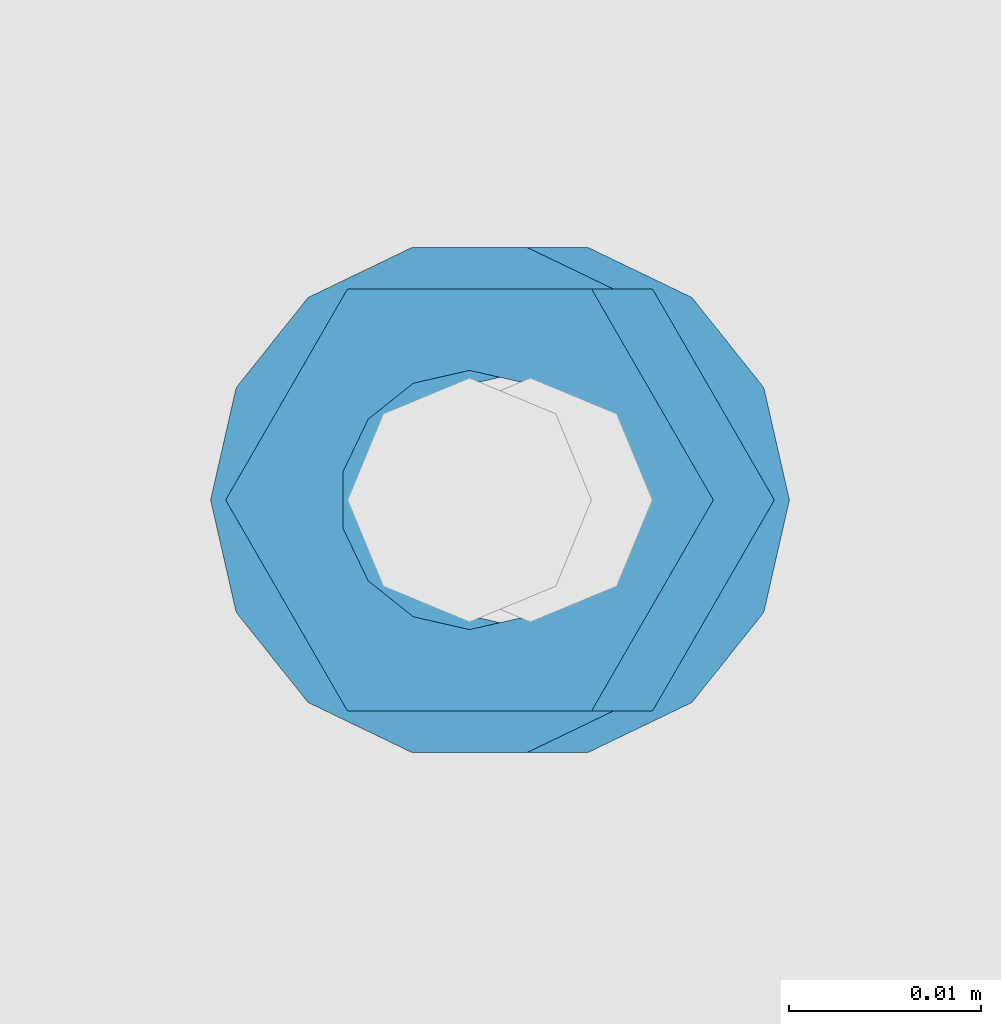
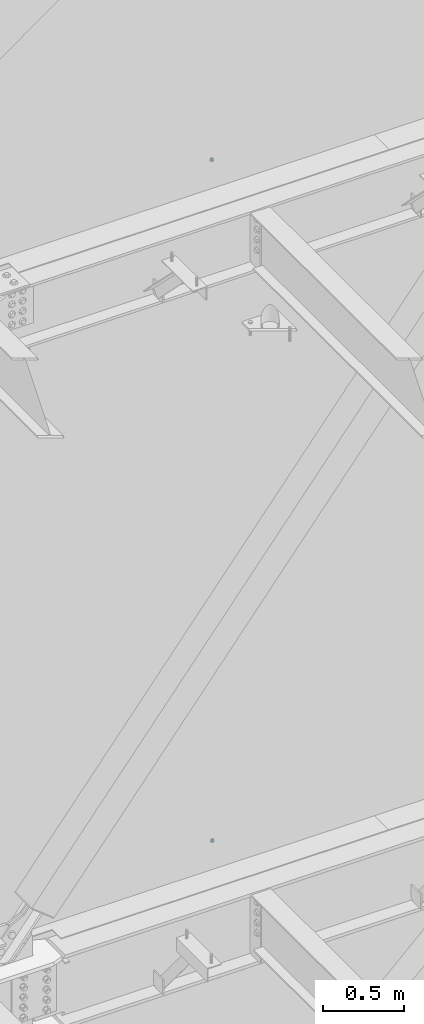
# One storey, part 668 of 1179: 4 columns, 2 elements without a shape of their own.
"""IFC2X3 building model written with IfcOpenShell, lengths in millimetres."""

from ifc_helpers import new_model, si_unit, frame, origin_with_axes, place, context, subcontext, project, spatial, faceted_brep, material, type_object, element, aggregate, save


model = new_model("IFC2X3")

# Units and contexts
model_context = context("Model", 3, precision=1e-05, world=origin_with_axes())
body_context = subcontext(model_context, "Body", "Model", "MODEL_VIEW")
ifc_project = project(units=[si_unit("LENGTHUNIT", "METRE", prefix="MILLI"), si_unit("AREAUNIT", "SQUARE_METRE"), si_unit("VOLUMEUNIT", "CUBIC_METRE"), si_unit("MASSUNIT", "GRAM", prefix="KILO"), si_unit("TIMEUNIT", "SECOND"), si_unit("PLANEANGLEUNIT", "RADIAN"), si_unit("SOLIDANGLEUNIT", "STERADIAN"), si_unit("THERMODYNAMICTEMPERATUREUNIT", "DEGREE_CELSIUS"), si_unit("LUMINOUSINTENSITYUNIT", "LUMEN")], contexts=[model_context])

# Site, building, storey
site_placement = place(None, origin_with_axes())
site = spatial("IfcSite", under=ifc_project, at=site_placement, CompositionType="ELEMENT")
building_placement = place(site_placement, origin_with_axes())
building = spatial("IfcBuilding", under=site, at=building_placement, Name="Undefined", CompositionType="ELEMENT")
storey_placement = place(building_placement, origin_with_axes())
storey = spatial("IfcBuildingStorey", under=building, at=storey_placement, Name="Undefined", CompositionType="ELEMENT", Elevation=0.0)

# Assembly, column
assembly_1_placement = place(storey_placement, origin_with_axes())
assembly_1 = element("IfcElementAssembly", 1, at=assembly_1_placement, inside=storey, Name="BEAM", AssemblyPlace="NOTDEFINED", PredefinedType="RIGID_FRAME")
ifc_material = material(Name="STEEL/A307")
column_type_1 = type_object("IfcColumnType", Name="1/2_WASHER", PredefinedType="NOTDEFINED")
column_1_placement = place(assembly_1_placement, frame((10236.2, 41529.0, 13252.45), z_axis=(0.0, 1.0, 0.0), x_axis=(0.0, 0.0, 1.0)))
column_1 = element("IfcColumn", 2, at=column_1_placement, type_object=column_type_1, material=ifc_material, Name="WASHER", ObjectType="1/2_WASHER", context=body_context, shape_type="Brep", body=[
    faceted_brep([(0.0, -13.4899997711182, 0.0), (0.0, -12.1540698217868, -5.85309154138758), (4.76249999999891, -12.1540698217868, -5.85309154138758), (4.76249999999891, -13.4899997711182, 0.0), (0.0, -8.41087728436833, -10.5469065195466), (4.76249999999891, -8.41087728436833, -10.5469065195466), (0.0, -3.00180734814057, -13.1517773121896), (4.76249999999891, -3.00180734814057, -13.1517773121896), (0.0, 3.00180734814057, -13.1517773121896), (4.76249999999891, 3.00180734814057, -13.1517773121896), (0.0, 8.41087728436833, -10.5469065195466), (4.76249999999891, 8.41087728436833, -10.5469065195466), (0.0, 12.1540698217868, -5.85309154138758), (4.76249999999891, 12.1540698217868, -5.85309154138758), (0.0, 13.4899997711182, 0.0), (4.76249999999891, 13.4899997711182, 0.0), (0.0, 12.1540698217868, 5.85309154138758), (4.76249999999891, 12.1540698217868, 5.85309154138758), (0.0, 8.41087728436833, 10.5469065195466), (4.76249999999891, 8.41087728436833, 10.5469065195466), (0.0, 3.00180734814057, 13.1517773121896), (4.76249999999891, 3.00180734814057, 13.1517773121896), (0.0, -3.00180734814057, 13.1517773121896), (4.76249999999891, -3.00180734814057, 13.1517773121896), (0.0, -8.41087728436833, 10.5469065195466), (4.76249999999891, -8.41087728436833, 10.5469065195466), (0.0, -12.1540698217868, 5.85309154138758), (4.76249999999891, -12.1540698217868, 5.85309154138758), (0.0, 0.0, 6.75), (0.0, 2.9287152390425, 6.08153985834178), (4.76249999999891, 2.9287152390425, 6.08153985834178), (4.76249999999891, 0.0, 6.75), (0.0, 5.27736250665839, 4.2085561625463), (4.76249999999891, 5.27736250665839, 4.2085561625463), (0.0, 6.58076340722619, 1.50201630420543), (4.76249999999891, 6.58076340722619, 1.50201630420543), (0.0, 6.58076340722619, -1.50201630420543), (4.76249999999891, 6.58076340722619, -1.50201630420543), (0.0, 5.27736250665839, -4.2085561625463), (4.76249999999891, 5.27736250665839, -4.2085561625463), (0.0, 2.9287152390425, -6.08153985834088), (4.76249999999891, 2.9287152390425, -6.08153985834088), (0.0, 0.0, -6.75), (4.76249999999891, 0.0, -6.75), (0.0, -2.9287152390425, -6.08153985834178), (4.76249999999891, -2.9287152390425, -6.08153985834178), (0.0, -5.27736250665839, -4.2085561625463), (4.76249999999891, -5.27736250665839, -4.2085561625463), (0.0, -6.58076340722619, -1.50201630420543), (4.76249999999891, -6.58076340722619, -1.50201630420543), (0.0, -6.58076340722619, 1.50201630420543), (4.76249999999891, -6.58076340722619, 1.50201630420543), (0.0, -5.27736250665839, 4.2085561625463), (4.76249999999891, -5.27736250665839, 4.2085561625463), (0.0, -2.9287152390425, 6.08153985834088), (4.76249999999891, -2.9287152390425, 6.08153985834088)], [[[0, 1, 2, 3]], [[1, 4, 5, 2]], [[4, 6, 7, 5]], [[6, 8, 9, 7]], [[8, 10, 11, 9]], [[10, 12, 13, 11]], [[12, 14, 15, 13]], [[14, 16, 17, 15]], [[16, 18, 19, 17]], [[18, 20, 21, 19]], [[20, 22, 23, 21]], [[22, 24, 25, 23]], [[24, 26, 27, 25]], [[26, 0, 3, 27]], [[28, 29, 30, 31]], [[29, 32, 33, 30]], [[32, 34, 35, 33]], [[34, 36, 37, 35]], [[36, 38, 39, 37]], [[38, 40, 41, 39]], [[40, 42, 43, 41]], [[42, 44, 45, 43]], [[44, 46, 47, 45]], [[46, 48, 49, 47]], [[48, 50, 51, 49]], [[50, 52, 53, 51]], [[52, 54, 55, 53]], [[54, 28, 31, 55]], [[5, 7, 9, 11, 13, 15, 17, 19, 21, 23, 25, 27, 3, 2], [33, 35, 37, 39, 41, 43, 45, 47, 49, 51, 53, 55, 31, 30]], [[26, 24, 22, 20, 18, 16, 14, 12, 10, 8, 6, 4, 1, 0], [54, 52, 50, 48, 46, 44, 42, 40, 38, 36, 34, 32, 29, 28]]]),
])

assembly_2_placement = place(storey_placement, origin_with_axes())
assembly_2 = element("IfcElementAssembly", 3, at=assembly_2_placement, inside=storey, Name="BEAM", AssemblyPlace="NOTDEFINED", PredefinedType="RIGID_FRAME")
column_2_placement = place(assembly_2_placement, frame((10239.375, 41529.0, 8147.05), z_axis=(0.0, 1.0, 0.0), x_axis=(0.0, 0.0, 1.0)))
column_2 = element("IfcColumn", 4, at=column_2_placement, type_object=column_type_1, material=ifc_material, Name="WASHER", ObjectType="1/2_WASHER", context=body_context, shape_type="Brep", body=[
    faceted_brep([(0.0, -13.4899997711182, 0.0), (0.0, -12.1540698217868, -5.85309154138758), (4.76249999999891, -12.1540698217868, -5.85309154138758), (4.76249999999891, -13.4899997711182, 0.0), (0.0, -8.41087728436833, -10.5469065195466), (4.76249999999891, -8.41087728436833, -10.5469065195466), (0.0, -3.00180734814057, -13.1517773121896), (4.76249999999891, -3.00180734814057, -13.1517773121896), (0.0, 3.00180734814057, -13.1517773121896), (4.76249999999891, 3.00180734814057, -13.1517773121896), (0.0, 8.41087728436833, -10.5469065195466), (4.76249999999891, 8.41087728436833, -10.5469065195466), (0.0, 12.1540698217868, -5.85309154138758), (4.76249999999891, 12.1540698217868, -5.85309154138758), (0.0, 13.4899997711182, 0.0), (4.76249999999891, 13.4899997711182, 0.0), (0.0, 12.1540698217868, 5.85309154138758), (4.76249999999891, 12.1540698217868, 5.85309154138758), (0.0, 8.41087728436833, 10.5469065195466), (4.76249999999891, 8.41087728436833, 10.5469065195466), (0.0, 3.00180734814057, 13.1517773121896), (4.76249999999891, 3.00180734814057, 13.1517773121896), (0.0, -3.00180734814057, 13.1517773121896), (4.76249999999891, -3.00180734814057, 13.1517773121896), (0.0, -8.41087728436833, 10.5469065195466), (4.76249999999891, -8.41087728436833, 10.5469065195466), (0.0, -12.1540698217868, 5.85309154138758), (4.76249999999891, -12.1540698217868, 5.85309154138758), (0.0, 0.0, 6.75), (0.0, 2.9287152390425, 6.08153985834178), (4.76249999999891, 2.9287152390425, 6.08153985834178), (4.76249999999891, 0.0, 6.75), (0.0, 5.27736250665839, 4.2085561625463), (4.76249999999891, 5.27736250665839, 4.2085561625463), (0.0, 6.58076340722619, 1.50201630420543), (4.76249999999891, 6.58076340722619, 1.50201630420543), (0.0, 6.58076340722619, -1.50201630420543), (4.76249999999891, 6.58076340722619, -1.50201630420543), (0.0, 5.27736250665839, -4.2085561625463), (4.76249999999891, 5.27736250665839, -4.2085561625463), (0.0, 2.9287152390425, -6.08153985834088), (4.76249999999891, 2.9287152390425, -6.08153985834088), (0.0, 0.0, -6.75), (4.76249999999891, 0.0, -6.75), (0.0, -2.9287152390425, -6.08153985834178), (4.76249999999891, -2.9287152390425, -6.08153985834178), (0.0, -5.27736250665839, -4.2085561625463), (4.76249999999891, -5.27736250665839, -4.2085561625463), (0.0, -6.58076340722619, -1.50201630420543), (4.76249999999891, -6.58076340722619, -1.50201630420543), (0.0, -6.58076340722619, 1.50201630420543), (4.76249999999891, -6.58076340722619, 1.50201630420543), (0.0, -5.27736250665839, 4.2085561625463), (4.76249999999891, -5.27736250665839, 4.2085561625463), (0.0, -2.9287152390425, 6.08153985834088), (4.76249999999891, -2.9287152390425, 6.08153985834088)], [[[0, 1, 2, 3]], [[1, 4, 5, 2]], [[4, 6, 7, 5]], [[6, 8, 9, 7]], [[8, 10, 11, 9]], [[10, 12, 13, 11]], [[12, 14, 15, 13]], [[14, 16, 17, 15]], [[16, 18, 19, 17]], [[18, 20, 21, 19]], [[20, 22, 23, 21]], [[22, 24, 25, 23]], [[24, 26, 27, 25]], [[26, 0, 3, 27]], [[28, 29, 30, 31]], [[29, 32, 33, 30]], [[32, 34, 35, 33]], [[34, 36, 37, 35]], [[36, 38, 39, 37]], [[38, 40, 41, 39]], [[40, 42, 43, 41]], [[42, 44, 45, 43]], [[44, 46, 47, 45]], [[46, 48, 49, 47]], [[48, 50, 51, 49]], [[50, 52, 53, 51]], [[52, 54, 55, 53]], [[54, 28, 31, 55]], [[5, 7, 9, 11, 13, 15, 17, 19, 21, 23, 25, 27, 3, 2], [33, 35, 37, 39, 41, 43, 45, 47, 49, 51, 53, 55, 31, 30]], [[26, 24, 22, 20, 18, 16, 14, 12, 10, 8, 6, 4, 1, 0], [54, 52, 50, 48, 46, 44, 42, 40, 38, 36, 34, 32, 29, 28]]]),
])

# Column
column_type_2 = type_object("IfcColumnType", Name="1/2_HEAVY_HEX_NUT", PredefinedType="NOTDEFINED")
column_3_placement = place(assembly_1_placement, frame((10236.2, 41529.0, 13257.2125), z_axis=(0.0, 1.0, 0.0), x_axis=(0.0, 0.0, 1.0)))
column_3 = element("IfcColumn", 5, at=column_3_placement, type_object=column_type_2, material=ifc_material, Name="NUT", ObjectType="1/2_HEAVY_HEX_NUT", context=body_context, shape_type="Brep", body=[
    faceted_brep([(0.0, -12.7, 0.0), (0.0, -6.34999990463257, -11.0), (12.7000000000007, -6.34999990463257, -11.0), (12.7000000000007, -12.6999998092651, 0.0), (0.0, 6.34999990463257, -11.0), (12.7000000000007, 6.34999990463257, -11.0), (0.0, 12.7, 0.0), (12.7000000000007, 12.6999998092651, 0.0), (0.0, 6.34999990463257, 11.0), (12.7000000000007, 6.34999990463257, 11.0), (0.0, -6.34999990463257, 11.0), (12.7000000000007, -6.34999990463257, 11.0), (0.0, 0.0, 6.75), (0.0, 2.9287152390425, 6.08153985834178), (12.7000000000007, 2.9287152390425, 6.08153985834178), (12.7000000000007, 0.0, 6.75), (0.0, 5.27736250665839, 4.2085561625463), (12.7000000000007, 5.27736250665839, 4.2085561625463), (0.0, 6.58076340722619, 1.50201630420543), (12.7000000000007, 6.58076340722619, 1.50201630420543), (0.0, 6.58076340722619, -1.50201630420543), (12.7000000000007, 6.58076340722619, -1.50201630420543), (0.0, 5.27736250665839, -4.2085561625463), (12.7000000000007, 5.27736250665839, -4.2085561625463), (0.0, 2.9287152390425, -6.08153985834088), (12.7000000000007, 2.9287152390425, -6.08153985834088), (0.0, 0.0, -6.75), (12.7000000000007, 0.0, -6.75), (0.0, -2.9287152390425, -6.08153985834178), (12.7000000000007, -2.9287152390425, -6.08153985834178), (0.0, -5.27736250665839, -4.2085561625463), (12.7000000000007, -5.27736250665839, -4.2085561625463), (0.0, -6.58076340722619, -1.50201630420543), (12.7000000000007, -6.58076340722619, -1.50201630420543), (0.0, -6.58076340722619, 1.50201630420543), (12.7000000000007, -6.58076340722619, 1.50201630420543), (0.0, -5.27736250665839, 4.2085561625463), (12.7000000000007, -5.27736250665839, 4.2085561625463), (0.0, -2.9287152390425, 6.08153985834088), (12.7000000000007, -2.9287152390425, 6.08153985834088)], [[[0, 1, 2, 3]], [[1, 4, 5, 2]], [[4, 6, 7, 5]], [[6, 8, 9, 7]], [[8, 10, 11, 9]], [[10, 0, 3, 11]], [[12, 13, 14, 15]], [[13, 16, 17, 14]], [[16, 18, 19, 17]], [[18, 20, 21, 19]], [[20, 22, 23, 21]], [[22, 24, 25, 23]], [[24, 26, 27, 25]], [[26, 28, 29, 27]], [[28, 30, 31, 29]], [[30, 32, 33, 31]], [[32, 34, 35, 33]], [[34, 36, 37, 35]], [[36, 38, 39, 37]], [[38, 12, 15, 39]], [[5, 7, 9, 11, 3, 2], [17, 19, 21, 23, 25, 27, 29, 31, 33, 35, 37, 39, 15, 14]], [[10, 8, 6, 4, 1, 0], [38, 36, 34, 32, 30, 28, 26, 24, 22, 20, 18, 16, 13, 12]]]),
])

aggregate(assembly_1, [column_1, column_3])

column_4_placement = place(assembly_2_placement, frame((10239.375, 41529.0, 8151.8125), z_axis=(0.0, 1.0, 0.0), x_axis=(0.0, 0.0, 1.0)))
column_4 = element("IfcColumn", 6, at=column_4_placement, type_object=column_type_2, material=ifc_material, Name="NUT", ObjectType="1/2_HEAVY_HEX_NUT", context=body_context, shape_type="Brep", body=[
    faceted_brep([(0.0, -12.7, 0.0), (0.0, -6.34999990463257, -11.0), (12.7000000000007, -6.34999990463257, -11.0), (12.7000000000007, -12.6999998092651, 0.0), (0.0, 6.34999990463257, -11.0), (12.7000000000007, 6.34999990463257, -11.0), (0.0, 12.7, 0.0), (12.7000000000007, 12.6999998092651, 0.0), (0.0, 6.34999990463257, 11.0), (12.7000000000007, 6.34999990463257, 11.0), (0.0, -6.34999990463257, 11.0), (12.7000000000007, -6.34999990463257, 11.0), (0.0, 0.0, 6.75), (0.0, 2.9287152390425, 6.08153985834178), (12.7000000000007, 2.9287152390425, 6.08153985834178), (12.7000000000007, 0.0, 6.75), (0.0, 5.27736250665839, 4.2085561625463), (12.7000000000007, 5.27736250665839, 4.2085561625463), (0.0, 6.58076340722619, 1.50201630420543), (12.7000000000007, 6.58076340722619, 1.50201630420543), (0.0, 6.58076340722619, -1.50201630420543), (12.7000000000007, 6.58076340722619, -1.50201630420543), (0.0, 5.27736250665839, -4.2085561625463), (12.7000000000007, 5.27736250665839, -4.2085561625463), (0.0, 2.9287152390425, -6.08153985834088), (12.7000000000007, 2.9287152390425, -6.08153985834088), (0.0, 0.0, -6.75), (12.7000000000007, 0.0, -6.75), (0.0, -2.9287152390425, -6.08153985834178), (12.7000000000007, -2.9287152390425, -6.08153985834178), (0.0, -5.27736250665839, -4.2085561625463), (12.7000000000007, -5.27736250665839, -4.2085561625463), (0.0, -6.58076340722619, -1.50201630420543), (12.7000000000007, -6.58076340722619, -1.50201630420543), (0.0, -6.58076340722619, 1.50201630420543), (12.7000000000007, -6.58076340722619, 1.50201630420543), (0.0, -5.27736250665839, 4.2085561625463), (12.7000000000007, -5.27736250665839, 4.2085561625463), (0.0, -2.9287152390425, 6.08153985834088), (12.7000000000007, -2.9287152390425, 6.08153985834088)], [[[0, 1, 2, 3]], [[1, 4, 5, 2]], [[4, 6, 7, 5]], [[6, 8, 9, 7]], [[8, 10, 11, 9]], [[10, 0, 3, 11]], [[12, 13, 14, 15]], [[13, 16, 17, 14]], [[16, 18, 19, 17]], [[18, 20, 21, 19]], [[20, 22, 23, 21]], [[22, 24, 25, 23]], [[24, 26, 27, 25]], [[26, 28, 29, 27]], [[28, 30, 31, 29]], [[30, 32, 33, 31]], [[32, 34, 35, 33]], [[34, 36, 37, 35]], [[36, 38, 39, 37]], [[38, 12, 15, 39]], [[5, 7, 9, 11, 3, 2], [17, 19, 21, 23, 25, 27, 29, 31, 33, 35, 37, 39, 15, 14]], [[10, 8, 6, 4, 1, 0], [38, 36, 34, 32, 30, 28, 26, 24, 22, 20, 18, 16, 13, 12]]]),
])

aggregate(assembly_2, [column_2, column_4])

save(model, "model.ifc")
